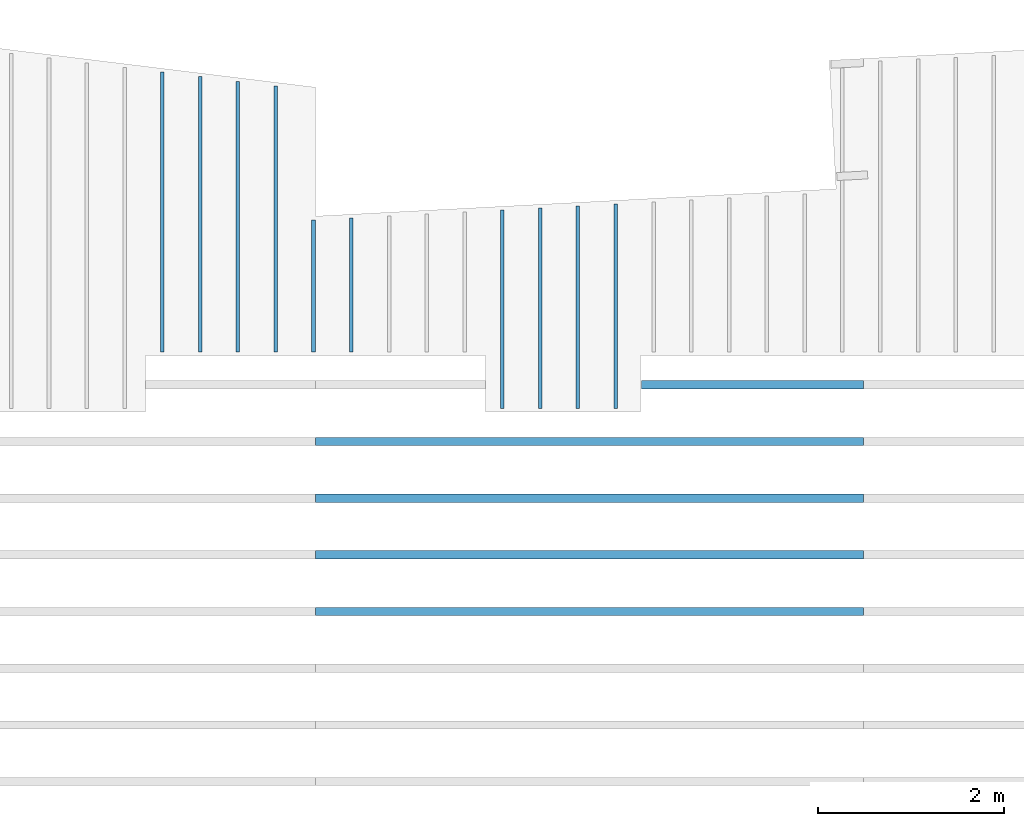
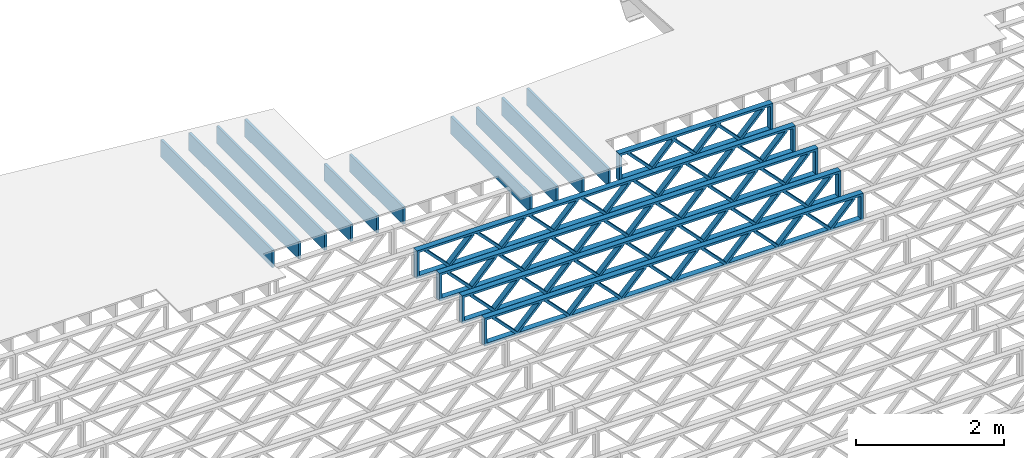
# One storey, part 9 of 12: 15 beams, 2 elements without a shape of their own.
"""IFC4 building model written with IfcOpenShell, lengths in feet."""

from ifc_helpers import new_model, entity, si_unit, converted_unit, derived_unit, direction, frame, frame_2d, origin, origin_2d_with_axis, place, context, subcontext, project, spatial, rectangle, extrude, source, transform, mapped, material, material_profile, profile_set, profile_usage, type_object, type_shapes, element, aggregate, save


model = new_model("IFC4")

# Units and contexts
model_context = context("Model", 3, precision=0.0001, world=origin(), true_north=direction((6.12303176911189e-17, 1.0)))
body_context = subcontext(model_context, "Body", "Model", "MODEL_VIEW")
ifc_project = project(units=[converted_unit("LENGTHUNIT", "FOOT", entity("IfcRatioMeasure", 0.3048), si_unit("LENGTHUNIT", "METRE"), dimensions=[1, 0, 0, 0, 0, 0, 0]), converted_unit("AREAUNIT", "SQUARE FOOT", entity("IfcRatioMeasure", 0.09290304), si_unit("AREAUNIT", "SQUARE_METRE"), dimensions=[2, 0, 0, 0, 0, 0, 0]), converted_unit("VOLUMEUNIT", "CUBIC FOOT", entity("IfcRatioMeasure", 0.028316846592), si_unit("VOLUMEUNIT", "CUBIC_METRE"), dimensions=[3, 0, 0, 0, 0, 0, 0]), converted_unit("PLANEANGLEUNIT", "DEGREE", entity("IfcRatioMeasure", 0.0174532925199433), si_unit("PLANEANGLEUNIT", "RADIAN"), dimensions=[0, 0, 0, 0, 0, 0, 0]), si_unit("MASSUNIT", "GRAM", prefix="KILO"), derived_unit("MASSDENSITYUNIT", [(si_unit("MASSUNIT", "GRAM", prefix="KILO"), 1), (si_unit("LENGTHUNIT", "METRE"), -3)]), derived_unit("MOMENTOFINERTIAUNIT", [(si_unit("LENGTHUNIT", "METRE"), 4)]), si_unit("TIMEUNIT", "SECOND"), si_unit("FREQUENCYUNIT", "HERTZ"), si_unit("THERMODYNAMICTEMPERATUREUNIT", "DEGREE_CELSIUS"), derived_unit("THERMALTRANSMITTANCEUNIT", [(si_unit("MASSUNIT", "GRAM", prefix="KILO"), 1), (si_unit("THERMODYNAMICTEMPERATUREUNIT", "KELVIN"), -1), (si_unit("TIMEUNIT", "SECOND"), -3)]), derived_unit("VOLUMETRICFLOWRATEUNIT", [(si_unit("LENGTHUNIT", "METRE"), 3), (si_unit("TIMEUNIT", "SECOND"), -1)]), si_unit("ELECTRICCURRENTUNIT", "AMPERE"), si_unit("ELECTRICVOLTAGEUNIT", "VOLT"), si_unit("POWERUNIT", "WATT"), si_unit("FORCEUNIT", "NEWTON"), si_unit("ILLUMINANCEUNIT", "LUX"), si_unit("LUMINOUSFLUXUNIT", "LUMEN"), si_unit("LUMINOUSINTENSITYUNIT", "CANDELA"), derived_unit("USERDEFINED", [(si_unit("MASSUNIT", "GRAM", prefix="KILO"), -1), (si_unit("LENGTHUNIT", "METRE"), -2), (si_unit("TIMEUNIT", "SECOND"), 3), (si_unit("LUMINOUSFLUXUNIT", "LUMEN"), 1)]), derived_unit("LINEARVELOCITYUNIT", [(si_unit("LENGTHUNIT", "METRE"), 1), (si_unit("TIMEUNIT", "SECOND"), -1)]), si_unit("PRESSUREUNIT", "PASCAL"), derived_unit("USERDEFINED", [(si_unit("LENGTHUNIT", "METRE"), -2), (si_unit("MASSUNIT", "GRAM", prefix="KILO"), 1), (si_unit("TIMEUNIT", "SECOND"), -2)]), derived_unit("LINEARFORCEUNIT", [(si_unit("MASSUNIT", "GRAM", prefix="KILO"), 1), (si_unit("LENGTHUNIT", "METRE"), 1), (si_unit("TIMEUNIT", "SECOND"), -2), (si_unit("LENGTHUNIT", "METRE"), -1)]), derived_unit("PLANARFORCEUNIT", [(si_unit("MASSUNIT", "GRAM", prefix="KILO"), 1), (si_unit("LENGTHUNIT", "METRE"), 1), (si_unit("TIMEUNIT", "SECOND"), -2), (si_unit("LENGTHUNIT", "METRE"), -2)])], contexts=[model_context])

# Site, building, storey
site_placement = place(None, origin())
site = spatial("IfcSite", under=ifc_project, at=site_placement, CompositionType="ELEMENT")
building_placement = place(site_placement, origin())
building = spatial("IfcBuilding", under=site, at=building_placement, CompositionType="ELEMENT")
storey_placement = place(building_placement, frame((0.0, 0.0, 21.46875)))
storey = spatial("IfcBuildingStorey", under=building, at=storey_placement, Name="3RD FLOOR", CompositionType="ELEMENT", Elevation=21.46875)

# Assembly, beams
assembly_1_placement = place(storey_placement, origin())
assembly_1 = element("IfcElementAssembly", 1, at=assembly_1_placement, inside=storey, Name="Structural Beam System:Structural Framing System", ObjectType="Structural Beam System:Structural Framing System", AssemblyPlace="NOTDEFINED", PredefinedType="BEAM_GRID")
ifc_material_1 = material(Name="WOOD TRUSS", Category="Materials")
ifc_material_profile_1 = material_profile(ifc_material_1, rectangle(XDim=1.73473973950632, YDim=0.125, at=frame_2d((-1.11022302462516e-16, 8.32667268468867e-17), x_axis=(1.0, 0.0))))
ifc_material_profile_2 = material_profile(ifc_material_1, rectangle(XDim=1.73473973950633, YDim=0.125, at=frame_2d((-1.11022302462516e-16, 8.32667268468867e-17), x_axis=(1.0, 0.0))))
ifc_material_profile_3 = material_profile(ifc_material_1, rectangle(XDim=1.73473973950632, YDim=0.125, at=frame_2d((-5.55111512312578e-17, 1.38777878078145e-16), x_axis=(1.0, 0.0))))
ifc_material_profile_4 = material_profile(ifc_material_1, rectangle(XDim=1.73473973950633, YDim=0.125, at=frame_2d((-1.11022302462516e-16, 8.32667268468867e-17), x_axis=(1.0, 0.0))))
ifc_material_profile_5 = material_profile(ifc_material_1, rectangle(XDim=1.73473973950632, YDim=0.125, at=frame_2d((-1.11022302462516e-16, 8.32667268468867e-17), x_axis=(1.0, 0.0))))
ifc_material_profile_6 = material_profile(ifc_material_1, rectangle(XDim=1.73473973950633, YDim=0.125, at=frame_2d((-2.77555756156289e-16, 3.05311331771918e-16), x_axis=(1.0, 0.0))))
ifc_material_profile_7 = material_profile(ifc_material_1, rectangle(XDim=1.73473973950632, YDim=0.124999999999999, at=frame_2d((-3.88578058618805e-16, -2.4980018054066e-16), x_axis=(1.0, 0.0))))
ifc_material_profile_8 = material_profile(ifc_material_1, rectangle(XDim=1.73473973950633, YDim=0.125, at=frame_2d((2.77555756156289e-16, -3.05311331771918e-16), x_axis=(1.0, 0.0))))
ifc_material_profile_9 = material_profile(ifc_material_1, rectangle(XDim=1.73473973950632, YDim=0.124999999999999, at=frame_2d((-1.11022302462516e-16, 8.32667268468867e-17), x_axis=(1.0, 0.0))))
ifc_material_profile_10 = material_profile(ifc_material_1, rectangle(XDim=1.73473973950633, YDim=0.125, at=origin_2d_with_axis()))
ifc_material_profile_11 = material_profile(ifc_material_1, rectangle(XDim=0.124999999999982, YDim=0.291666666666668, at=origin_2d_with_axis()))
ifc_material_profile_12 = material_profile(ifc_material_1, rectangle(XDim=0.124999999999932, YDim=0.291666666666664, at=origin_2d_with_axis()))
ifc_material_profile_13 = material_profile(ifc_material_1, rectangle(XDim=1.25000000000002, YDim=0.29166666666667, at=origin_2d_with_axis()))
ifc_material_profile_14 = material_profile(ifc_material_1, rectangle(XDim=1.25000000000004, YDim=0.291666666666667, at=origin_2d_with_axis()))
ifc_profile_set_1 = profile_set([ifc_material_profile_1, ifc_material_profile_2, ifc_material_profile_3, ifc_material_profile_4, ifc_material_profile_5, ifc_material_profile_6, ifc_material_profile_7, ifc_material_profile_8, ifc_material_profile_9, ifc_material_profile_10, ifc_material_profile_11, ifc_material_profile_12, ifc_material_profile_13, ifc_material_profile_14])
ifc_profile_usage_1 = profile_usage(ifc_profile_set_1, cardinal=8)
beam_type_1 = type_object("IfcBeamType", PredefinedType="BEAM", material=ifc_profile_set_1)
shared_shape_1 = source(origin(), body_context, "Body", "SweptSolid", [
    extrude(rectangle(XDim=1.73473973950632, YDim=0.125, at=frame_2d((-5.55111512312578e-17, 1.38777878078145e-16), x_axis=(1.0, 0.0))), frame((0.625142936836962, -0.145833333333334, 0.0), z_axis=(0.0, 1.0, 0.0), x_axis=(0.693383046997606, 0.0, 0.720569184836762)), (0.0, 0.0, 1.0), 0.291666666666667),
    extrude(rectangle(XDim=1.73473973950633, YDim=0.125, at=frame_2d((-1.11022302462516e-16, 8.32667268468867e-17), x_axis=(1.0, 0.0))), frame((-0.625142936836309, -0.145833333333334, 0.0), z_axis=(0.0, 1.0, 0.0), x_axis=(0.69338304699761, 0.0, -0.720569184836758)), (0.0, 0.0, 1.0), 0.291666666666667),
    extrude(rectangle(XDim=1.73473973950632, YDim=0.125, at=frame_2d((-1.11022302462516e-16, 8.32667268468867e-17), x_axis=(1.0, 0.0))), frame((2.87514283803796, -0.145833333333334, 0.0), z_axis=(0.0, 1.0, 0.0), x_axis=(0.693383046997606, 0.0, 0.720569184836762)), (0.0, 0.0, 1.0), 0.291666666666667),
    extrude(rectangle(XDim=1.73473973950633, YDim=0.125, at=frame_2d((-1.11022302462516e-16, 8.32667268468867e-17), x_axis=(1.0, 0.0))), frame((1.62485696436469, -0.145833333333334, 0.0), z_axis=(0.0, 1.0, 0.0), x_axis=(0.69338304699761, 0.0, -0.720569184836758)), (0.0, 0.0, 1.0), 0.291666666666667),
    extrude(rectangle(XDim=1.73473973950632, YDim=0.125, at=frame_2d((-1.11022302462516e-16, 8.32667268468867e-17), x_axis=(1.0, 0.0))), frame((-1.62485696436403, -0.145833333333334, 0.0), z_axis=(0.0, 1.0, 0.0), x_axis=(0.693383046997606, 0.0, 0.720569184836762)), (0.0, 0.0, 1.0), 0.291666666666667),
    extrude(rectangle(XDim=1.73473973950633, YDim=0.125, at=origin_2d_with_axis()), frame((-2.87514283803731, -0.145833333333334, 0.0), z_axis=(0.0, 1.0, 0.0), x_axis=(0.69338304699761, 0.0, -0.720569184836758)), (0.0, 0.0, 1.0), 0.291666666666667),
    extrude(rectangle(XDim=0.124999999999982, YDim=0.291666666666668, at=origin_2d_with_axis()), frame((-3.91666656786758, 0.0, 0.687500000000054), z_axis=(1.0, 0.0, 0.0), x_axis=(0.0, 0.0, -1.0)), (0.0, 0.0, 1.0), 7.83333313573516),
    extrude(rectangle(XDim=0.124999999999932, YDim=0.291666666666664, at=origin_2d_with_axis()), frame((-3.91666656786737, 0.0, -0.687499999999984), z_axis=(1.0, 0.0, 0.0), x_axis=(0.0, 0.0, -1.0)), (0.0, 0.0, 1.0), 7.83333313573495),
    extrude(rectangle(XDim=1.25000000000002, YDim=0.29166666666667, at=origin_2d_with_axis()), frame((3.79166656786756, 0.0, 0.0), z_axis=(1.0, 0.0, 0.0), x_axis=(0.0, 0.0, -1.0)), (0.0, 0.0, 1.0), 0.12500000000002),
    extrude(rectangle(XDim=1.25000000000004, YDim=0.291666666666667, at=origin_2d_with_axis()), frame((-3.91666656786758, 0.0, 0.0), z_axis=(1.0, 0.0, 0.0), x_axis=(0.0, 0.0, -1.0)), (0.0, 0.0, 1.0), 0.125000000000023),
])
type_shapes(beam_type_1, [shared_shape_1])
beam_1_placement = place(assembly_1_placement, frame((-168.321493720097, 957.861934882651, -0.947916666666661), z_axis=(0.0, 0.0, 1.0), x_axis=(-1.0, 0.0, 0.0)))
beam_1 = element("IfcBeam", 2, at=beam_1_placement, type_object=beam_type_1, material=ifc_profile_usage_1, PredefinedType="BEAM", context=body_context, shape_type="MappedRepresentation", body=[
    mapped(shared_shape_1, transform((0.0, 0.0, 0.0), scale=1.0)),
])
ifc_profile_usage_2 = profile_usage(ifc_profile_set_1, cardinal=8)
beam_type_2 = type_object("IfcBeamType", PredefinedType="BEAM", material=ifc_profile_set_1)
shared_shape_2 = source(origin(), body_context, "Body", "SweptSolid", [
    extrude(rectangle(XDim=1.73473973950632, YDim=0.124999999999999, at=frame_2d((5.55111512312578e-16, 7.21644966006352e-16), x_axis=(1.0, 0.0))), frame((5.95847627016997, -0.145833333333334, 0.0), z_axis=(0.0, 1.0, 0.0), x_axis=(0.693383046997606, 0.0, 0.720569184836762)), (0.0, 0.0, 1.0), 0.291666666666667),
    extrude(rectangle(XDim=1.73473973950633, YDim=0.125, at=origin_2d_with_axis()), frame((4.7081903964967, -0.145833333333334, 0.0), z_axis=(0.0, 1.0, 0.0), x_axis=(0.69338304699761, 0.0, -0.720569184836758)), (0.0, 0.0, 1.0), 0.291666666666666),
    extrude(rectangle(XDim=1.73473973950632, YDim=0.125, at=frame_2d((2.22044604925031e-16, 3.88578058618805e-16), x_axis=(1.0, 0.0))), frame((3.29180960350347, -0.145833333333334, 0.0), z_axis=(0.0, 1.0, 0.0), x_axis=(0.693383046997606, 0.0, 0.720569184836762)), (0.0, 0.0, 1.0), 0.291666666666667),
    extrude(rectangle(XDim=1.73473973950633, YDim=0.125, at=frame_2d((1.11022302462516e-16, -8.32667268468867e-17), x_axis=(1.0, 0.0))), frame((2.0415237298302, -0.145833333333334, 0.0), z_axis=(0.0, 1.0, 0.0), x_axis=(0.69338304699761, 0.0, -0.720569184836758)), (0.0, 0.0, 1.0), 0.291666666666667),
    extrude(rectangle(XDim=1.73473973950632, YDim=0.125, at=frame_2d((-5.55111512312578e-17, 1.38777878078145e-16), x_axis=(1.0, 0.0))), frame((0.625142936836964, -0.145833333333334, 0.0), z_axis=(0.0, 1.0, 0.0), x_axis=(0.693383046997606, 0.0, 0.720569184836762)), (0.0, 0.0, 1.0), 0.291666666666667),
    extrude(rectangle(XDim=1.73473973950633, YDim=0.125, at=frame_2d((-1.11022302462516e-16, 8.32667268468867e-17), x_axis=(1.0, 0.0))), frame((-0.625142936836306, -0.145833333333334, 0.0), z_axis=(0.0, 1.0, 0.0), x_axis=(0.69338304699761, 0.0, -0.720569184836758)), (0.0, 0.0, 1.0), 0.291666666666667),
    extrude(rectangle(XDim=1.73473973950632, YDim=0.125, at=frame_2d((-1.11022302462516e-16, 8.32667268468867e-17), x_axis=(1.0, 0.0))), frame((-2.04152372982954, -0.145833333333334, 0.0), z_axis=(0.0, 1.0, 0.0), x_axis=(0.693383046997606, 0.0, 0.720569184836762)), (0.0, 0.0, 1.0), 0.291666666666667),
    extrude(rectangle(XDim=1.73473973950633, YDim=0.125, at=origin_2d_with_axis()), frame((-3.29180960350281, -0.145833333333334, 0.0), z_axis=(0.0, 1.0, 0.0), x_axis=(0.69338304699761, 0.0, -0.720569184836758)), (0.0, 0.0, 1.0), 0.291666666666667),
    extrude(rectangle(XDim=1.73473973950632, YDim=0.124999999999999, at=frame_2d((-1.11022302462516e-16, 8.32667268468867e-17), x_axis=(1.0, 0.0))), frame((-4.70819039649604, -0.145833333333334, 0.0), z_axis=(0.0, 1.0, 0.0), x_axis=(0.693383046997606, 0.0, 0.720569184836762)), (0.0, 0.0, 1.0), 0.291666666666667),
    extrude(rectangle(XDim=1.73473973950633, YDim=0.125, at=frame_2d((-5.55111512312578e-16, 6.38378239159465e-16), x_axis=(1.0, 0.0))), frame((-5.95847627016931, -0.145833333333334, 0.0), z_axis=(0.0, 1.0, 0.0), x_axis=(0.69338304699761, 0.0, -0.720569184836758)), (0.0, 0.0, 1.0), 0.291666666666666),
    extrude(rectangle(XDim=1.73473973950632, YDim=0.125, at=frame_2d((-7.21644966006352e-16, -5.82867087928207e-16), x_axis=(1.0, 0.0))), frame((8.62514293683647, -0.145833333333334, 0.0), z_axis=(0.0, 1.0, 0.0), x_axis=(0.693383046997607, 0.0, 0.720569184836761)), (0.0, 0.0, 1.0), 0.291666666666667),
    extrude(rectangle(XDim=1.73473973950633, YDim=0.125, at=origin_2d_with_axis()), frame((7.3748570631632, -0.145833333333334, 0.0), z_axis=(0.0, 1.0, 0.0), x_axis=(0.69338304699761, 0.0, -0.720569184836758)), (0.0, 0.0, 1.0), 0.291666666666666),
    extrude(rectangle(XDim=1.73473973950632, YDim=0.124999999999999, at=frame_2d((-1.11022302462516e-16, 8.32667268468867e-17), x_axis=(1.0, 0.0))), frame((-7.37485706316255, -0.145833333333334, 0.0), z_axis=(0.0, 1.0, 0.0), x_axis=(0.693383046997606, 0.0, 0.720569184836762)), (0.0, 0.0, 1.0), 0.291666666666667),
    extrude(rectangle(XDim=1.73473973950633, YDim=0.125, at=origin_2d_with_axis()), frame((-8.62514293683582, -0.145833333333334, 0.0), z_axis=(0.0, 1.0, 0.0), x_axis=(0.69338304699761, 0.0, -0.720569184836758)), (0.0, 0.0, 1.0), 0.291666666666666),
    extrude(rectangle(XDim=0.124999999999982, YDim=0.291666666666668, at=origin_2d_with_axis()), frame((-9.66666666666609, 0.0, 0.687500000000054), z_axis=(1.0, 0.0, 0.0), x_axis=(0.0, 0.0, -1.0)), (0.0, 0.0, 1.0), 19.3333333333322),
    extrude(rectangle(XDim=0.124999999999932, YDim=0.291666666666664, at=origin_2d_with_axis()), frame((-9.66666666666588, 0.0, -0.687499999999984), z_axis=(1.0, 0.0, 0.0), x_axis=(0.0, 0.0, -1.0)), (0.0, 0.0, 1.0), 19.333333333332),
    extrude(rectangle(XDim=1.25000000000002, YDim=0.29166666666667, at=origin_2d_with_axis()), frame((9.54166666666607, 0.0, 0.0), z_axis=(1.0, 0.0, 0.0), x_axis=(0.0, 0.0, -1.0)), (0.0, 0.0, 1.0), 0.12500000000002),
    extrude(rectangle(XDim=1.25000000000004, YDim=0.291666666666667, at=origin_2d_with_axis()), frame((-9.66666666666609, 0.0, 0.0), z_axis=(1.0, 0.0, 0.0), x_axis=(0.0, 0.0, -1.0)), (0.0, 0.0, 1.0), 0.125000000000023),
])
type_shapes(beam_type_2, [shared_shape_2])
beam_2_placement = place(assembly_1_placement, frame((-174.071493818896, 953.861934882651, -0.947916666666661), z_axis=(0.0, 0.0, 1.0), x_axis=(-1.0, 0.0, 0.0)))
beam_2 = element("IfcBeam", 3, at=beam_2_placement, type_object=beam_type_2, material=ifc_profile_usage_2, PredefinedType="BEAM", context=body_context, shape_type="MappedRepresentation", body=[
    mapped(shared_shape_2, transform((0.0, 0.0, 0.0), scale=1.0)),
])
ifc_profile_usage_3 = profile_usage(ifc_profile_set_1, cardinal=8)
beam_3_placement = place(assembly_1_placement, frame((-174.071493818896, 951.861934882651, -0.947916666666661), z_axis=(0.0, 0.0, 1.0), x_axis=(-1.0, 0.0, 0.0)))
beam_3 = element("IfcBeam", 4, at=beam_3_placement, type_object=beam_type_2, material=ifc_profile_usage_3, PredefinedType="BEAM", context=body_context, shape_type="MappedRepresentation", body=[
    mapped(shared_shape_2, transform((0.0, 0.0, 0.0), scale=1.0)),
])
ifc_profile_usage_4 = profile_usage(ifc_profile_set_1, cardinal=8)
beam_4_placement = place(assembly_1_placement, frame((-174.071493818896, 949.861934882651, -0.947916666666661), z_axis=(0.0, 0.0, 1.0), x_axis=(-1.0, 0.0, 0.0)))
beam_4 = element("IfcBeam", 5, at=beam_4_placement, type_object=beam_type_2, material=ifc_profile_usage_4, PredefinedType="BEAM", context=body_context, shape_type="MappedRepresentation", body=[
    mapped(shared_shape_2, transform((0.0, 0.0, 0.0), scale=1.0)),
])
ifc_profile_usage_5 = profile_usage(ifc_profile_set_1, cardinal=8)
beam_type_3 = type_object("IfcBeamType", PredefinedType="BEAM", material=ifc_profile_set_1)
shared_shape_3 = source(origin(), body_context, "Body", "SweptSolid", [
    extrude(rectangle(XDim=1.73473973950632, YDim=0.124999999999999, at=frame_2d((5.55111512312578e-16, 7.21644966006352e-16), x_axis=(1.0, 0.0))), frame((5.95847627016997, -0.145833333333334, 0.0), z_axis=(0.0, 1.0, 0.0), x_axis=(0.693383046997606, 0.0, 0.720569184836762)), (0.0, 0.0, 1.0), 0.291666666666667),
    extrude(rectangle(XDim=1.73473973950633, YDim=0.125, at=origin_2d_with_axis()), frame((4.7081903964967, -0.145833333333334, 0.0), z_axis=(0.0, 1.0, 0.0), x_axis=(0.69338304699761, 0.0, -0.720569184836758)), (0.0, 0.0, 1.0), 0.291666666666666),
    extrude(rectangle(XDim=1.73473973950632, YDim=0.125, at=frame_2d((2.22044604925031e-16, 3.88578058618805e-16), x_axis=(1.0, 0.0))), frame((3.29180960350347, -0.145833333333334, 0.0), z_axis=(0.0, 1.0, 0.0), x_axis=(0.693383046997606, 0.0, 0.720569184836762)), (0.0, 0.0, 1.0), 0.291666666666667),
    extrude(rectangle(XDim=1.73473973950633, YDim=0.125, at=frame_2d((1.11022302462516e-16, -8.32667268468867e-17), x_axis=(1.0, 0.0))), frame((2.0415237298302, -0.145833333333334, 0.0), z_axis=(0.0, 1.0, 0.0), x_axis=(0.69338304699761, 0.0, -0.720569184836758)), (0.0, 0.0, 1.0), 0.291666666666667),
    extrude(rectangle(XDim=1.73473973950632, YDim=0.125, at=frame_2d((-5.55111512312578e-17, 1.38777878078145e-16), x_axis=(1.0, 0.0))), frame((0.625142936836964, -0.145833333333334, 0.0), z_axis=(0.0, 1.0, 0.0), x_axis=(0.693383046997606, 0.0, 0.720569184836762)), (0.0, 0.0, 1.0), 0.291666666666667),
    extrude(rectangle(XDim=1.73473973950633, YDim=0.125, at=frame_2d((-1.11022302462516e-16, 8.32667268468867e-17), x_axis=(1.0, 0.0))), frame((-0.625142936836306, -0.145833333333334, 0.0), z_axis=(0.0, 1.0, 0.0), x_axis=(0.69338304699761, 0.0, -0.720569184836758)), (0.0, 0.0, 1.0), 0.291666666666667),
    extrude(rectangle(XDim=1.73473973950632, YDim=0.125, at=frame_2d((-1.11022302462516e-16, 8.32667268468867e-17), x_axis=(1.0, 0.0))), frame((-2.04152372982954, -0.145833333333334, 0.0), z_axis=(0.0, 1.0, 0.0), x_axis=(0.693383046997606, 0.0, 0.720569184836762)), (0.0, 0.0, 1.0), 0.291666666666667),
    extrude(rectangle(XDim=1.73473973950633, YDim=0.125, at=origin_2d_with_axis()), frame((-3.29180960350281, -0.145833333333334, 0.0), z_axis=(0.0, 1.0, 0.0), x_axis=(0.69338304699761, 0.0, -0.720569184836758)), (0.0, 0.0, 1.0), 0.291666666666667),
    extrude(rectangle(XDim=1.73473973950632, YDim=0.124999999999999, at=frame_2d((-1.11022302462516e-16, 8.32667268468867e-17), x_axis=(1.0, 0.0))), frame((-4.70819039649604, -0.145833333333334, 0.0), z_axis=(0.0, 1.0, 0.0), x_axis=(0.693383046997606, 0.0, 0.720569184836762)), (0.0, 0.0, 1.0), 0.291666666666667),
    extrude(rectangle(XDim=1.73473973950633, YDim=0.125, at=frame_2d((-5.55111512312578e-16, 6.38378239159465e-16), x_axis=(1.0, 0.0))), frame((-5.95847627016931, -0.145833333333334, 0.0), z_axis=(0.0, 1.0, 0.0), x_axis=(0.69338304699761, 0.0, -0.720569184836758)), (0.0, 0.0, 1.0), 0.291666666666666),
    extrude(rectangle(XDim=1.73473973950632, YDim=0.125, at=frame_2d((-7.21644966006352e-16, -5.82867087928207e-16), x_axis=(1.0, 0.0))), frame((8.62514293683647, -0.145833333333334, 0.0), z_axis=(0.0, 1.0, 0.0), x_axis=(0.693383046997607, 0.0, 0.720569184836761)), (0.0, 0.0, 1.0), 0.291666666666667),
    extrude(rectangle(XDim=1.73473973950633, YDim=0.125, at=origin_2d_with_axis()), frame((7.3748570631632, -0.145833333333334, 0.0), z_axis=(0.0, 1.0, 0.0), x_axis=(0.69338304699761, 0.0, -0.720569184836758)), (0.0, 0.0, 1.0), 0.291666666666666),
    extrude(rectangle(XDim=1.73473973950632, YDim=0.124999999999999, at=frame_2d((-1.11022302462516e-16, 8.32667268468867e-17), x_axis=(1.0, 0.0))), frame((-7.37485706316255, -0.145833333333334, 0.0), z_axis=(0.0, 1.0, 0.0), x_axis=(0.693383046997606, 0.0, 0.720569184836762)), (0.0, 0.0, 1.0), 0.291666666666667),
    extrude(rectangle(XDim=1.73473973950633, YDim=0.125, at=origin_2d_with_axis()), frame((-8.62514293683582, -0.145833333333334, 0.0), z_axis=(0.0, 1.0, 0.0), x_axis=(0.69338304699761, 0.0, -0.720569184836758)), (0.0, 0.0, 1.0), 0.291666666666666),
    extrude(rectangle(XDim=0.124999999999982, YDim=0.291666666666668, at=origin_2d_with_axis()), frame((-9.66666666666609, 0.0, 0.687500000000054), z_axis=(1.0, 0.0, 0.0), x_axis=(0.0, 0.0, -1.0)), (0.0, 0.0, 1.0), 19.3333333333322),
    extrude(rectangle(XDim=0.124999999999932, YDim=0.291666666666664, at=origin_2d_with_axis()), frame((-9.66666666666588, 0.0, -0.687499999999984), z_axis=(1.0, 0.0, 0.0), x_axis=(0.0, 0.0, -1.0)), (0.0, 0.0, 1.0), 19.333333333332),
    extrude(rectangle(XDim=1.25000000000002, YDim=0.29166666666667, at=origin_2d_with_axis()), frame((9.54166666666607, 0.0, 0.0), z_axis=(1.0, 0.0, 0.0), x_axis=(0.0, 0.0, -1.0)), (0.0, 0.0, 1.0), 0.12500000000002),
    extrude(rectangle(XDim=1.25000000000004, YDim=0.291666666666667, at=origin_2d_with_axis()), frame((-9.66666666666609, 0.0, 0.0), z_axis=(1.0, 0.0, 0.0), x_axis=(0.0, 0.0, -1.0)), (0.0, 0.0, 1.0), 0.125000000000023),
])
type_shapes(beam_type_3, [shared_shape_3])
beam_5_placement = place(assembly_1_placement, frame((-174.071493818896, 955.861934882651, -0.947916666666661), z_axis=(0.0, 0.0, 1.0), x_axis=(-1.0, 0.0, 0.0)))
beam_5 = element("IfcBeam", 6, at=beam_5_placement, type_object=beam_type_3, material=ifc_profile_usage_5, PredefinedType="BEAM", context=body_context, shape_type="MappedRepresentation", body=[
    mapped(shared_shape_3, transform((0.0, 0.0, 0.0), scale=1.0)),
])
aggregate(assembly_1, [beam_1, beam_5, beam_2, beam_3, beam_4])

assembly_2_placement = place(storey_placement, origin())
assembly_2 = element("IfcElementAssembly", 7, at=assembly_2_placement, inside=storey, Name="Structural Beam System:Structural Framing System", ObjectType="Structural Beam System:Structural Framing System", AssemblyPlace="NOTDEFINED", PredefinedType="BEAM_GRID")
ifc_material_2 = material(Category="Materials")
ifc_material_profile_15 = material_profile(ifc_material_2, rectangle(XDim=0.9375, YDim=0.125000000000011, at=origin_2d_with_axis()))
ifc_profile_set_2 = profile_set([ifc_material_profile_15])
ifc_profile_usage_6 = profile_usage(ifc_profile_set_2, cardinal=8)
beam_type_4 = type_object("IfcBeamType", PredefinedType="BEAM", material=ifc_profile_set_2)
shared_shape_4 = source(origin(), body_context, "Body", "SweptSolid", [
    extrude(rectangle(XDim=0.9375, YDim=0.125000000000011, at=origin_2d_with_axis()), frame((-4.93557821271736, 0.0, 0.0), z_axis=(1.0, 0.0, 0.0), x_axis=(0.0, 0.0, -1.0)), (0.0, 0.0, 1.0), 9.87115642543472),
])
type_shapes(beam_type_4, [shared_shape_4])
beam_6_placement = place(assembly_2_placement, frame((-189.144289395965, 963.964179744199, -0.729166666666714), z_axis=(0.0, 0.0, 1.0), x_axis=(0.0, 1.0, 0.0)))
beam_6 = element("IfcBeam", 8, at=beam_6_placement, type_object=beam_type_4, material=ifc_profile_usage_6, PredefinedType="BEAM", context=body_context, shape_type="MappedRepresentation", body=[
    mapped(shared_shape_4, transform((0.0, 0.0, 0.0), scale=1.0)),
])
ifc_profile_usage_7 = profile_usage(ifc_profile_set_2, cardinal=8)
beam_type_5 = type_object("IfcBeamType", PredefinedType="BEAM", material=ifc_profile_set_2)
shared_shape_5 = source(origin(), body_context, "Body", "SweptSolid", [
    extrude(rectangle(XDim=0.9375, YDim=0.125000000000011, at=origin_2d_with_axis()), frame((-4.85372200628331, 0.0, 0.0), z_axis=(1.0, 0.0, 0.0), x_axis=(0.0, 0.0, -1.0)), (0.0, 0.0, 1.0), 9.70744401256661),
])
type_shapes(beam_type_5, [shared_shape_5])
beam_7_placement = place(assembly_2_placement, frame((-187.810956062631, 963.882323202763, -0.729166666666714), z_axis=(0.0, 0.0, 1.0), x_axis=(0.0, 1.0, 0.0)))
beam_7 = element("IfcBeam", 9, at=beam_7_placement, type_object=beam_type_5, material=ifc_profile_usage_7, PredefinedType="BEAM", context=body_context, shape_type="MappedRepresentation", body=[
    mapped(shared_shape_5, transform((0.0, 0.0, 0.0), scale=1.0)),
])
ifc_profile_usage_8 = profile_usage(ifc_profile_set_2, cardinal=8)
beam_type_6 = type_object("IfcBeamType", PredefinedType="BEAM", material=ifc_profile_set_2)
shared_shape_6 = source(origin(), body_context, "Body", "SweptSolid", [
    extrude(rectangle(XDim=0.9375, YDim=0.125000000000011, at=origin_2d_with_axis()), frame((-4.77186579984931, 0.0, 0.0), z_axis=(1.0, 0.0, 0.0), x_axis=(0.0, 0.0, -1.0)), (0.0, 0.0, 1.0), 9.54373159969862),
])
type_shapes(beam_type_6, [shared_shape_6])
beam_8_placement = place(assembly_2_placement, frame((-186.477622729298, 963.800466661326, -0.729166666666714), z_axis=(0.0, 0.0, 1.0), x_axis=(0.0, 1.0, 0.0)))
beam_8 = element("IfcBeam", 10, at=beam_8_placement, type_object=beam_type_6, material=ifc_profile_usage_8, PredefinedType="BEAM", context=body_context, shape_type="MappedRepresentation", body=[
    mapped(shared_shape_6, transform((0.0, 0.0, 0.0), scale=1.0)),
])
ifc_profile_usage_9 = profile_usage(ifc_profile_set_2, cardinal=8)
beam_type_7 = type_object("IfcBeamType", PredefinedType="BEAM", material=ifc_profile_set_2)
shared_shape_7 = source(origin(), body_context, "Body", "SweptSolid", [
    extrude(rectangle(XDim=0.9375, YDim=0.125000000000011, at=origin_2d_with_axis()), frame((-4.69000959341525, 0.0, 0.0), z_axis=(1.0, 0.0, 0.0), x_axis=(0.0, 0.0, -1.0)), (0.0, 0.0, 1.0), 9.38001918683051),
])
type_shapes(beam_type_7, [shared_shape_7])
beam_9_placement = place(assembly_2_placement, frame((-185.144289395965, 963.71861011989, -0.729166666666714), z_axis=(0.0, 0.0, 1.0), x_axis=(0.0, 1.0, 0.0)))
beam_9 = element("IfcBeam", 11, at=beam_9_placement, type_object=beam_type_7, material=ifc_profile_usage_9, PredefinedType="BEAM", context=body_context, shape_type="MappedRepresentation", body=[
    mapped(shared_shape_7, transform((0.0, 0.0, 0.0), scale=1.0)),
])
ifc_profile_usage_10 = profile_usage(ifc_profile_set_2, cardinal=8)
beam_type_8 = type_object("IfcBeamType", PredefinedType="BEAM", material=ifc_profile_set_2)
shared_shape_8 = source(origin(), body_context, "Body", "SweptSolid", [
    extrude(rectangle(XDim=0.9375, YDim=0.125000000000011, at=origin_2d_with_axis()), frame((-2.32822434331121, 0.0, 0.0), z_axis=(1.0, 0.0, 0.0), x_axis=(0.0, 0.0, -1.0)), (0.0, 0.0, 1.0), 4.6564486846224),
])
type_shapes(beam_type_8, [shared_shape_8])
beam_10_placement = place(assembly_2_placement, frame((-183.810956062631, 961.356824534783, -0.729166666666714), z_axis=(0.0, 0.0, 1.0), x_axis=(0.0, 1.0, 0.0)))
beam_10 = element("IfcBeam", 12, at=beam_10_placement, type_object=beam_type_8, material=ifc_profile_usage_10, PredefinedType="BEAM", context=body_context, shape_type="MappedRepresentation", body=[
    mapped(shared_shape_8, transform((0.0, 0.0, 0.0), scale=1.0)),
])
ifc_profile_usage_11 = profile_usage(ifc_profile_set_2, cardinal=8)
beam_type_9 = type_object("IfcBeamType", PredefinedType="BEAM", material=ifc_profile_set_2)
shared_shape_9 = source(origin(), body_context, "Body", "SweptSolid", [
    extrude(rectangle(XDim=0.9375, YDim=0.125000000000011, at=origin_2d_with_axis()), frame((-2.36316303033436, 0.0, 0.0), z_axis=(1.0, 0.0, 0.0), x_axis=(0.0, 0.0, -1.0)), (0.0, 0.0, 1.0), 4.72632606066873),
])
type_shapes(beam_type_9, [shared_shape_9])
beam_11_placement = place(assembly_2_placement, frame((-182.477622729298, 961.391762886804, -0.729166666666714), z_axis=(0.0, 0.0, 1.0), x_axis=(0.0, 1.0, 0.0)))
beam_11 = element("IfcBeam", 13, at=beam_11_placement, type_object=beam_type_9, material=ifc_profile_usage_11, PredefinedType="BEAM", context=body_context, shape_type="MappedRepresentation", body=[
    mapped(shared_shape_9, transform((0.0, 0.0, 0.0), scale=1.0)),
])
ifc_profile_usage_12 = profile_usage(ifc_profile_set_2, cardinal=8)
beam_type_10 = type_object("IfcBeamType", PredefinedType="BEAM", material=ifc_profile_set_2)
shared_shape_10 = source(origin(), body_context, "Body", "SweptSolid", [
    extrude(rectangle(XDim=0.9375, YDim=0.125000000000011, at=origin_2d_with_axis()), frame((-3.50291792614212, 0.0, 0.0), z_axis=(1.0, 0.0, 0.0), x_axis=(0.0, 0.0, -1.0)), (0.0, 0.0, 1.0), 7.00583585228424),
])
type_shapes(beam_type_10, [shared_shape_10])
beam_12_placement = place(assembly_2_placement, frame((-177.144289395965, 960.531516147172, -0.729166666666714), z_axis=(0.0, 0.0, 1.0), x_axis=(0.0, 1.0, 0.0)))
beam_12 = element("IfcBeam", 14, at=beam_12_placement, type_object=beam_type_10, material=ifc_profile_usage_12, PredefinedType="BEAM", context=body_context, shape_type="MappedRepresentation", body=[
    mapped(shared_shape_10, transform((0.0, 0.0, 0.0), scale=1.0)),
])
ifc_profile_usage_13 = profile_usage(ifc_profile_set_2, cardinal=8)
beam_type_11 = type_object("IfcBeamType", PredefinedType="BEAM", material=ifc_profile_set_2)
shared_shape_11 = source(origin(), body_context, "Body", "SweptSolid", [
    extrude(rectangle(XDim=0.9375, YDim=0.125000000000011, at=origin_2d_with_axis()), frame((-3.53785644566409, 0.0, 0.0), z_axis=(1.0, 0.0, 0.0), x_axis=(0.0, 0.0, -1.0)), (0.0, 0.0, 1.0), 7.07571289132818),
])
type_shapes(beam_type_11, [shared_shape_11])
beam_13_placement = place(assembly_2_placement, frame((-175.810956062631, 960.566454666694, -0.729166666666714), z_axis=(0.0, 0.0, 1.0), x_axis=(0.0, 1.0, 0.0)))
beam_13 = element("IfcBeam", 15, at=beam_13_placement, type_object=beam_type_11, material=ifc_profile_usage_13, PredefinedType="BEAM", context=body_context, shape_type="MappedRepresentation", body=[
    mapped(shared_shape_11, transform((0.0, 0.0, 0.0), scale=1.0)),
])
ifc_profile_usage_14 = profile_usage(ifc_profile_set_2, cardinal=8)
beam_type_12 = type_object("IfcBeamType", PredefinedType="BEAM", material=ifc_profile_set_2)
shared_shape_12 = source(origin(), body_context, "Body", "SweptSolid", [
    extrude(rectangle(XDim=0.9375, YDim=0.125000000000011, at=origin_2d_with_axis()), frame((-3.57279496518601, 0.0, 0.0), z_axis=(1.0, 0.0, 0.0), x_axis=(0.0, 0.0, -1.0)), (0.0, 0.0, 1.0), 7.14558993037201),
])
type_shapes(beam_type_12, [shared_shape_12])
beam_14_placement = place(assembly_2_placement, frame((-174.477622729298, 960.601393186216, -0.729166666666714), z_axis=(0.0, 0.0, 1.0), x_axis=(0.0, 1.0, 0.0)))
beam_14 = element("IfcBeam", 16, at=beam_14_placement, type_object=beam_type_12, material=ifc_profile_usage_14, PredefinedType="BEAM", context=body_context, shape_type="MappedRepresentation", body=[
    mapped(shared_shape_12, transform((0.0, 0.0, 0.0), scale=1.0)),
])
ifc_profile_usage_15 = profile_usage(ifc_profile_set_2, cardinal=8)
beam_type_13 = type_object("IfcBeamType", PredefinedType="BEAM", material=ifc_profile_set_2)
shared_shape_13 = source(origin(), body_context, "Body", "SweptSolid", [
    extrude(rectangle(XDim=0.9375, YDim=0.125000000000011, at=origin_2d_with_axis()), frame((-3.60773348470792, 0.0, 0.0), z_axis=(1.0, 0.0, 0.0), x_axis=(0.0, 0.0, -1.0)), (0.0, 0.0, 1.0), 7.21546696941584),
])
type_shapes(beam_type_13, [shared_shape_13])
beam_15_placement = place(assembly_2_placement, frame((-173.144289395965, 960.636331705738, -0.729166666666714), z_axis=(0.0, 0.0, 1.0), x_axis=(0.0, 1.0, 0.0)))
beam_15 = element("IfcBeam", 17, at=beam_15_placement, type_object=beam_type_13, material=ifc_profile_usage_15, PredefinedType="BEAM", context=body_context, shape_type="MappedRepresentation", body=[
    mapped(shared_shape_13, transform((0.0, 0.0, 0.0), scale=1.0)),
])
aggregate(assembly_2, [beam_6, beam_7, beam_8, beam_9, beam_10, beam_11, beam_12, beam_13, beam_14, beam_15])

save(model, "model.ifc")
